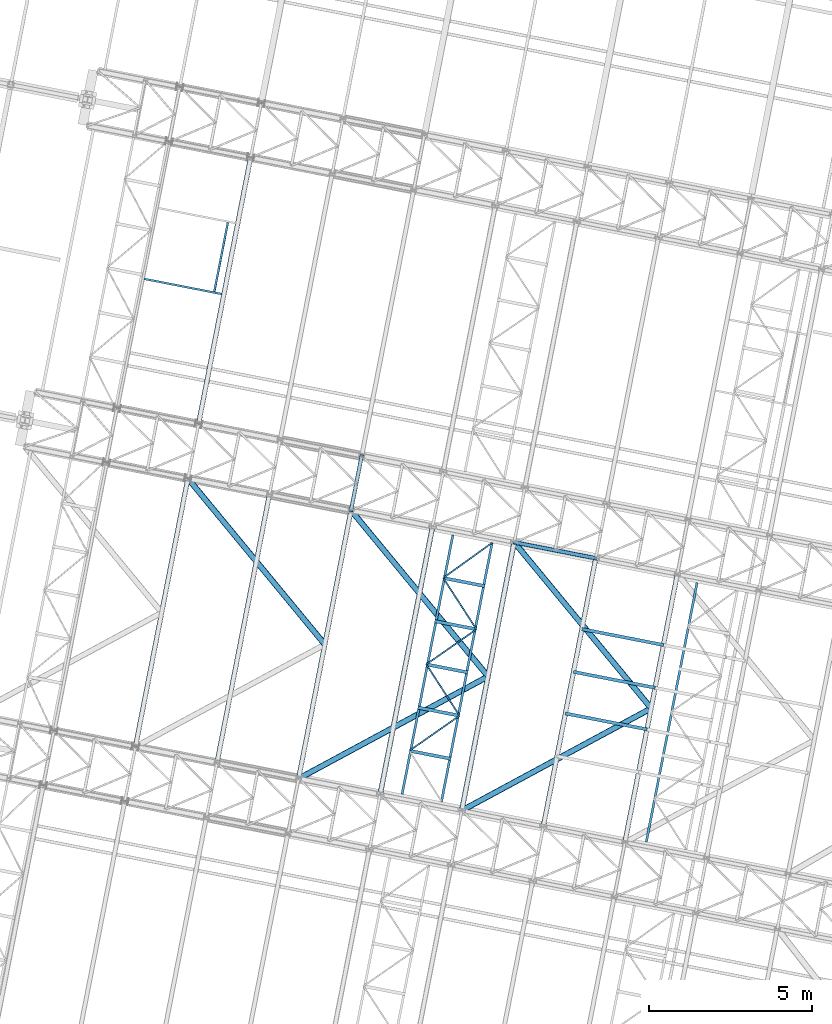
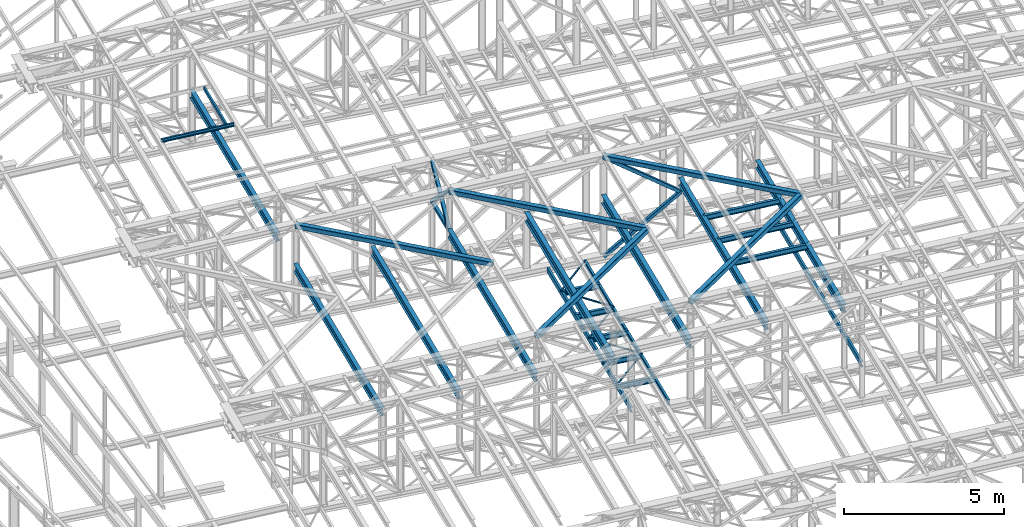
# One storey, part 74 of 215: 32 beams, 4 members, 36 elements without a shape of their own.
"""IFC2X3 building model written with IfcOpenShell, lengths in millimetres."""

from ifc_helpers import new_model, si_unit, frame, origin_with_axes, origin_2d_with_axis, place, context, subcontext, project, spatial, hollow_rectangle, i_section, u_section, extrude, material, type_object, element, aggregate, save


model = new_model("IFC2X3")

# Units and contexts
model_context = context("Model", 3, precision=1e-05, world=origin_with_axes())
body_context = subcontext(model_context, "Body", "Model", "MODEL_VIEW")
ifc_project = project(units=[si_unit("LENGTHUNIT", "METRE", prefix="MILLI"), si_unit("AREAUNIT", "SQUARE_METRE"), si_unit("VOLUMEUNIT", "CUBIC_METRE"), si_unit("MASSUNIT", "GRAM", prefix="KILO"), si_unit("TIMEUNIT", "SECOND"), si_unit("PLANEANGLEUNIT", "RADIAN"), si_unit("SOLIDANGLEUNIT", "STERADIAN"), si_unit("THERMODYNAMICTEMPERATUREUNIT", "DEGREE_CELSIUS"), si_unit("LUMINOUSINTENSITYUNIT", "LUMEN")], contexts=[model_context])

# Site, building, storey
site_placement = place(None, origin_with_axes())
site = spatial("IfcSite", under=ifc_project, at=site_placement, CompositionType="ELEMENT")
building_placement = place(site_placement, origin_with_axes())
building = spatial("IfcBuilding", under=site, at=building_placement, Name="Undefined", CompositionType="ELEMENT")
storey_placement = place(building_placement, origin_with_axes())
storey = spatial("IfcBuildingStorey", under=building, at=storey_placement, Name="Undefined", CompositionType="ELEMENT", Elevation=0.0)

# Assembly, beam
assembly_1_placement = place(storey_placement, origin_with_axes())
assembly_1 = element("IfcElementAssembly", 1, at=assembly_1_placement, inside=storey, Name="Steel Assembly", AssemblyPlace="NOTDEFINED", PredefinedType="RIGID_FRAME")
ifc_material_1 = material(Name="STEEL/S275JR")
beam_type_1 = type_object("IfcBeamType", PredefinedType="NOTDEFINED")
beam_1_placement = place(assembly_1_placement, frame((56068.4883392099, 40051.9911039338, 10796.0000010585), z_axis=(0.981422364268518, -0.191859461052493, -0.000300197000082615), x_axis=(0.191859470081235, 0.981422408415534, 0.0)))
beam_1 = element("IfcBeam", 2, at=beam_1_placement, type_object=beam_type_1, material=ifc_material_1, context=body_context, shape_type="SweptSolid", body=[
    extrude(hollow_rectangle(XDim=120.0, YDim=120.0, WallThickness=5.0, InnerFilletRadius=5.0, OuterFilletRadius=10.0, at=origin_2d_with_axis()), frame((1699.99999941724, 1.81898940354586e-12, 0.0), z_axis=(-1.0, 0.0, 0.0), x_axis=(-6.93889390390723e-18, -1.0, -3.46944695195361e-18)), (0.0, 0.0, 1.0), 1700.0),
])
aggregate(assembly_1, [beam_1])

assembly_2_placement = place(storey_placement, origin_with_axes())
assembly_2 = element("IfcElementAssembly", 3, at=assembly_2_placement, inside=storey, Name="Steel Assembly", AssemblyPlace="NOTDEFINED", PredefinedType="RIGID_FRAME")
beam_type_2 = type_object("IfcBeamType", PredefinedType="NOTDEFINED")
beam_2_placement = place(assembly_2_placement, frame((59388.9839819225, 33770.6286614, 8745.0), z_axis=(0.0, 0.0, -1.0), x_axis=(-0.819693302763381, -0.57280266183465, 0.0)))
beam_2 = element("IfcBeam", 4, at=beam_2_placement, type_object=beam_type_2, material=ifc_material_1, context=body_context, shape_type="SweptSolid", body=[
    extrude(hollow_rectangle(XDim=50.0, YDim=50.0, WallThickness=3.0, InnerFilletRadius=3.0, OuterFilletRadius=6.0, at=origin_2d_with_axis()), frame((1872.18331006399, -1.71506235268826e-12, -1.81898940354586e-12), z_axis=(-1.0, 0.0, 0.0), x_axis=(-6.93889390390723e-18, -1.0, -3.46944695195361e-18)), (0.0, 0.0, 1.0), 1872.2),
])
aggregate(assembly_2, [beam_2])

assembly_3_placement = place(storey_placement, origin_with_axes())
assembly_3 = element("IfcElementAssembly", 5, at=assembly_3_placement, inside=storey, Name="Steel Assembly", AssemblyPlace="NOTDEFINED", PredefinedType="RIGID_FRAME")
beam_3_placement = place(assembly_3_placement, frame((58371.9008317393, 35341.8559067744, 8745.0), z_axis=(0.0, 0.0, -1.0), x_axis=(0.54340443190272, -0.839471037849718, 0.0)))
beam_3 = element("IfcBeam", 6, at=beam_3_placement, type_object=beam_type_2, material=ifc_material_1, context=body_context, shape_type="SweptSolid", body=[
    extrude(hollow_rectangle(XDim=50.0, YDim=50.0, WallThickness=3.0, InnerFilletRadius=3.0, OuterFilletRadius=6.0, at=origin_2d_with_axis()), frame((1871.68725783601, 1.03899514427353e-13, 0.0), z_axis=(-1.0, 0.0, 0.0), x_axis=(-6.93889390390723e-18, -1.0, -3.46944695195361e-18)), (0.0, 0.0, 1.0), 1871.7),
])
aggregate(assembly_3, [beam_3])

assembly_4_placement = place(storey_placement, origin_with_axes())
assembly_4 = element("IfcElementAssembly", 7, at=assembly_4_placement, inside=storey, Name="Steel Assembly", AssemblyPlace="NOTDEFINED", PredefinedType="RIGID_FRAME")
beam_4_placement = place(assembly_4_placement, frame((59906.5169523149, 36414.2474905055, 8745.0), z_axis=(0.0, 0.0, -1.0), x_axis=(-0.819693302763381, -0.57280266183465, 0.0)))
beam_4 = element("IfcBeam", 8, at=beam_4_placement, type_object=beam_type_2, material=ifc_material_1, context=body_context, shape_type="SweptSolid", body=[
    extrude(hollow_rectangle(XDim=50.0, YDim=50.0, WallThickness=3.0, InnerFilletRadius=3.0, OuterFilletRadius=6.0, at=origin_2d_with_axis()), frame((1872.18331006399, -1.71506235268826e-12, -1.81898940354586e-12), z_axis=(-1.0, 0.0, 0.0), x_axis=(-6.93889390390723e-18, -1.0, -3.46944695195361e-18)), (0.0, 0.0, 1.0), 1872.2),
])
aggregate(assembly_4, [beam_4])

assembly_5_placement = place(storey_placement, origin_with_axes())
assembly_5 = element("IfcElementAssembly", 9, at=assembly_5_placement, inside=storey, Name="Steel Assembly", AssemblyPlace="NOTDEFINED", PredefinedType="RIGID_FRAME")
beam_5_placement = place(assembly_5_placement, frame((58889.4338021317, 37985.47473588, 8745.0), z_axis=(0.0, 0.0, -1.0), x_axis=(0.54340443190272, -0.839471037849718, 0.0)))
beam_5 = element("IfcBeam", 10, at=beam_5_placement, type_object=beam_type_2, material=ifc_material_1, context=body_context, shape_type="SweptSolid", body=[
    extrude(hollow_rectangle(XDim=50.0, YDim=50.0, WallThickness=3.0, InnerFilletRadius=3.0, OuterFilletRadius=6.0, at=origin_2d_with_axis()), frame((1871.68725783601, 1.03899514427353e-13, 0.0), z_axis=(-1.0, 0.0, 0.0), x_axis=(-6.93889390390723e-18, -1.0, -3.46944695195361e-18)), (0.0, 0.0, 1.0), 1871.7),
])
aggregate(assembly_5, [beam_5])

assembly_6_placement = place(storey_placement, origin_with_axes())
assembly_6 = element("IfcElementAssembly", 11, at=assembly_6_placement, inside=storey, Name="Steel Assembly", AssemblyPlace="NOTDEFINED", PredefinedType="RIGID_FRAME")
beam_6_placement = place(assembly_6_placement, frame((60379.3501328525, 39057.9928599236, 8745.0), z_axis=(0.0, 0.0, -1.0), x_axis=(-0.811591585333054, -0.584225212239749, 0.0)))
beam_6 = element("IfcBeam", 12, at=beam_6_placement, type_object=beam_type_2, material=ifc_material_1, context=body_context, shape_type="SweptSolid", body=[
    extrude(hollow_rectangle(XDim=50.0, YDim=50.0, WallThickness=3.0, InnerFilletRadius=3.0, OuterFilletRadius=6.0, at=origin_2d_with_axis()), frame((1835.79568552319, -2.03814263857537e-13, 0.0), z_axis=(-1.0, 0.0, 0.0), x_axis=(-6.93889390390723e-18, -1.0, -3.46944695195361e-18)), (0.0, 0.0, 1.0), 1835.8),
])
aggregate(assembly_6, [beam_6])

assembly_7_placement = place(storey_placement, origin_with_axes())
assembly_7 = element("IfcElementAssembly", 13, at=assembly_7_placement, inside=storey, Name="Steel Assembly", AssemblyPlace="NOTDEFINED", PredefinedType="RIGID_FRAME")
ifc_material_2 = material(Name="STEEL/S235JR")
beam_type_3 = type_object("IfcBeamType", Name="UPN140", PredefinedType="NOTDEFINED")
beam_7_placement = place(assembly_7_placement, frame((51886.3079063828, 46748.6428343733, 12209.6470870652), z_axis=(-0.0304080349967745, 0.00594450299936818, 0.999519891893966), x_axis=(0.191921834917674, 0.981410214579016, 1.34299999948354e-06)))
beam_7 = element("IfcBeam", 14, at=beam_7_placement, type_object=beam_type_3, material=ifc_material_2, ObjectType="UPN140", context=body_context, shape_type="SweptSolid", body=[
    extrude(u_section(Depth=140.0, FlangeWidth=60.0, WebThickness=7.0, FlangeThickness=10.0, FilletRadius=10.0, EdgeRadius=5.0, FlangeSlope=0.0798299857122373, at=origin_2d_with_axis()), frame((2150.00000378023, 7.26605124323266e-12, 2.48810634737501e-15), z_axis=(-1.0, 0.0, 0.0), x_axis=(-6.93889390390723e-18, -1.0, -3.46944695195361e-18)), (0.0, 0.0, 1.0), 2150.0),
])
aggregate(assembly_7, [beam_7])

assembly_8_placement = place(storey_placement, origin_with_axes())
assembly_8 = element("IfcElementAssembly", 15, at=assembly_8_placement, inside=storey, Name="Steel Assembly", AssemblyPlace="NOTDEFINED", PredefinedType="RIGID_FRAME")
beam_8_placement = place(assembly_8_placement, frame((49742.0858907209, 47137.3036134857, 12142.1026785298), z_axis=(-0.0304080349967745, 0.00594450299936818, 0.999519891893966), x_axis=(0.9809472788136, -0.191787511963556, 0.0309836479941128)))
beam_8 = element("IfcBeam", 16, at=beam_8_placement, type_object=beam_type_3, material=ifc_material_2, ObjectType="UPN140", context=body_context, shape_type="SweptSolid", body=[
    extrude(u_section(Depth=140.0, FlangeWidth=60.0, WebThickness=7.0, FlangeThickness=10.0, FilletRadius=10.0, EdgeRadius=5.0, FlangeSlope=0.0798299857122373, at=origin_2d_with_axis()), frame((2424.69780127148, -3.7379625959944e-14, 0.0), z_axis=(-1.0, 0.0, 0.0), x_axis=(-6.93889390390723e-18, -1.0, -3.46944695195361e-18)), (0.0, 0.0, 1.0), 2424.7),
])
aggregate(assembly_8, [beam_8])

assembly_9_placement = place(storey_placement, origin_with_axes())
assembly_9 = element("IfcElementAssembly", 17, at=assembly_9_placement, inside=storey, Name="Steel Assembly", AssemblyPlace="NOTDEFINED", PredefinedType="RIGID_FRAME")
beam_type_4 = type_object("IfcBeamType", Name="UPN200", PredefinedType="NOTDEFINED")
beam_9_placement = place(assembly_9_placement, frame((59185.001716299, 39300.0796500561, 8670.00000003361), z_axis=(0.0, 0.0, -1.0), x_axis=(-0.192120010045405, -0.981371439231932, 0.0)))
beam_9 = element("IfcBeam", 18, at=beam_9_placement, type_object=beam_type_4, material=ifc_material_1, ObjectType="UPN200", context=body_context, shape_type="SweptSolid", body=[
    extrude(u_section(Depth=200.0, FlangeWidth=75.0, WebThickness=8.5, FlangeThickness=11.5, FilletRadius=11.5, EdgeRadius=6.0, FlangeSlope=0.0798299857122373, at=origin_2d_with_axis()), frame((8081.40136371167, 0.0, 0.0), z_axis=(-1.0, 0.0, 0.0), x_axis=(-6.93889390390723e-18, -1.0, -3.46944695195361e-18)), (0.0, 0.0, 1.0), 8081.4),
])
aggregate(assembly_9, [beam_9])

assembly_10_placement = place(storey_placement, origin_with_axes())
assembly_10 = element("IfcElementAssembly", 19, at=assembly_10_placement, inside=storey, Name="Steel Assembly", AssemblyPlace="NOTDEFINED", PredefinedType="RIGID_FRAME")
beam_10_placement = place(assembly_10_placement, frame((58834.648904857, 31134.2149317573, 8670.00000000005), z_axis=(0.0, 0.0, -1.0), x_axis=(0.192120705997516, 0.981371302987313, 0.0)))
beam_10 = element("IfcBeam", 20, at=beam_10_placement, type_object=beam_type_4, material=ifc_material_1, ObjectType="UPN200", context=body_context, shape_type="SweptSolid", body=[
    extrude(u_section(Depth=200.0, FlangeWidth=75.0, WebThickness=8.5, FlangeThickness=11.5, FilletRadius=11.5, EdgeRadius=6.0, FlangeSlope=0.0798299857122373, at=origin_2d_with_axis()), frame((8081.40136371167, 0.0, 0.0), z_axis=(-1.0, 0.0, 0.0), x_axis=(-6.93889390390723e-18, -1.0, -3.46944695195361e-18)), (0.0, 0.0, 1.0), 8081.4),
])
aggregate(assembly_10, [beam_10])

assembly_11_placement = place(storey_placement, origin_with_axes())
assembly_11 = element("IfcElementAssembly", 21, at=assembly_11_placement, inside=storey, Name="Steel Assembly", AssemblyPlace="NOTDEFINED", PredefinedType="RIGID_FRAME")
beam_11_placement = place(assembly_11_placement, frame((66657.3309576963, 37839.3049389897, 8670.00000003361), z_axis=(0.0, 0.0, -1.0), x_axis=(-0.192122339055983, -0.981370983285963, 0.0)))
beam_11 = element("IfcBeam", 22, at=beam_11_placement, type_object=beam_type_4, material=ifc_material_1, ObjectType="UPN200", context=body_context, shape_type="SweptSolid", body=[
    extrude(u_section(Depth=200.0, FlangeWidth=75.0, WebThickness=8.5, FlangeThickness=11.5, FilletRadius=11.5, EdgeRadius=6.0, FlangeSlope=0.0798299857122373, at=origin_2d_with_axis()), frame((8081.40136371167, 0.0, 0.0), z_axis=(-1.0, 0.0, 0.0), x_axis=(-6.93889390390723e-18, -1.0, -3.46944695195361e-18)), (0.0, 0.0, 1.0), 8081.4),
])
aggregate(assembly_11, [beam_11])

# Assembly, member
assembly_12_placement = place(storey_placement, origin_with_axes())
assembly_12 = element("IfcElementAssembly", 23, at=assembly_12_placement, inside=storey, Name="Steel Assembly", AssemblyPlace="NOTDEFINED", PredefinedType="RIGID_FRAME")
member_type = type_object("IfcMemberType", PredefinedType="NOTDEFINED")
member_1_placement = place(assembly_12_placement, frame((56394.649437903, 41720.409197756, 10796.0000010567), z_axis=(0.981461316285517, -0.191660209055757, 0.000221133000063429), x_axis=(-0.1413283100442, -0.722939399226104, 0.676302398211518)))
member_1 = element("IfcMember", 24, at=member_1_placement, type_object=member_type, material=ifc_material_1, context=body_context, shape_type="SweptSolid", body=[
    extrude(hollow_rectangle(XDim=120.0, YDim=120.0, WallThickness=5.0, InnerFilletRadius=5.0, OuterFilletRadius=10.0, at=origin_2d_with_axis()), frame((2307.82564529445, -1.28110058411315e-13, 8.31339197405457e-14), z_axis=(-1.0, 0.0, 0.0), x_axis=(-6.93889390390723e-18, -1.0, -3.46944695195361e-18)), (0.0, 0.0, 1.0), 2307.8),
])
aggregate(assembly_12, [member_1])

assembly_13_placement = place(storey_placement, origin_with_axes())
assembly_13 = element("IfcElementAssembly", 25, at=assembly_13_placement, inside=storey, Name="Steel Assembly", AssemblyPlace="NOTDEFINED", PredefinedType="RIGID_FRAME")
member_2_placement = place(assembly_13_placement, frame((56068.4883392099, 40051.9911039338, 10796.0000010585), z_axis=(0.981461316285734, -0.1916602090558, -0.000221132000064958), x_axis=(0.141328309922255, 0.722939402602315, 0.67630239462797)))
member_2 = element("IfcMember", 26, at=member_2_placement, type_object=member_type, material=ifc_material_1, context=body_context, shape_type="SweptSolid", body=[
    extrude(hollow_rectangle(XDim=120.0, YDim=120.0, WallThickness=5.0, InnerFilletRadius=5.0, OuterFilletRadius=10.0, at=origin_2d_with_axis()), frame((2307.82564529445, -1.28110058411315e-13, 8.31339197405457e-14), z_axis=(-1.0, 0.0, 0.0), x_axis=(-6.93889390390723e-18, -1.0, -3.46944695195361e-18)), (0.0, 0.0, 1.0), 2307.8),
])
aggregate(assembly_13, [member_2])

assembly_14_placement = place(storey_placement, origin_with_axes())
assembly_14 = element("IfcElementAssembly", 27, at=assembly_14_placement, inside=storey, Name="Steel Assembly", AssemblyPlace="NOTDEFINED", PredefinedType="RIGID_FRAME")
member_3_placement = place(assembly_14_placement, frame((61060.8069352431, 39075.3484803415, 8655.0000016707), z_axis=(0.586579985276589, -0.114671755054075, -0.801732068378043), x_axis=(0.786837687269709, -0.153820555052726, 0.597683604204872)))
member_3 = element("IfcMember", 28, at=member_3_placement, type_object=member_type, material=ifc_material_1, context=body_context, shape_type="SweptSolid", body=[
    extrude(hollow_rectangle(XDim=120.0, YDim=120.0, WallThickness=5.0, InnerFilletRadius=5.0, OuterFilletRadius=10.0, at=origin_2d_with_axis()), frame((3174.34353524926, -3.64367411917281e-14, -3.63797880709171e-12), z_axis=(-1.0, 0.0, 0.0), x_axis=(-6.93889390390723e-18, -1.0, -3.46944695195361e-18)), (0.0, 0.0, 1.0), 3174.3),
])
aggregate(assembly_14, [member_3])

assembly_15_placement = place(storey_placement, origin_with_axes())
assembly_15 = element("IfcElementAssembly", 29, at=assembly_15_placement, inside=storey, Name="Steel Assembly", AssemblyPlace="NOTDEFINED", PredefinedType="RIGID_FRAME")
member_4_placement = place(assembly_15_placement, frame((61065.6495561053, 39075.0898102343, 12449.5061705353), z_axis=(-0.5871579940314, 0.114784234006137, -0.80129274904285), x_axis=(0.786406660116399, -0.153735599022755, -0.598272455088553)))
member_4 = element("IfcMember", 30, at=member_4_placement, type_object=member_type, material=ifc_material_1, context=body_context, shape_type="SweptSolid", body=[
    extrude(hollow_rectangle(XDim=120.0, YDim=120.0, WallThickness=5.0, InnerFilletRadius=5.0, OuterFilletRadius=10.0, at=origin_2d_with_axis()), frame((3171.03698575571, 7.28100941696481e-12, -3.52055827352395e-13), z_axis=(-1.0, 0.0, 0.0), x_axis=(-6.93889390390723e-18, -1.0, -3.46944695195361e-18)), (0.0, 0.0, 1.0), 3171.0),
])
aggregate(assembly_15, [member_4])

# Assembly, beam
assembly_16_placement = place(storey_placement, origin_with_axes())
assembly_16 = element("IfcElementAssembly", 31, at=assembly_16_placement, inside=storey, Name="Steel Assembly", AssemblyPlace="NOTDEFINED", PredefinedType="RIGID_FRAME")
beam_type_5 = type_object("IfcBeamType", PredefinedType="NOTDEFINED")
beam_12_placement = place(assembly_16_placement, frame((55270.4855326497, 35948.1553562493, 12311.8085914758), z_axis=(-0.0304080349967745, 0.00594450299936818, 0.999519891893966), x_axis=(-0.636209844962318, 0.771144499954326, -0.023941456998582)))
beam_12 = element("IfcBeam", 32, at=beam_12_placement, type_object=beam_type_5, material=ifc_material_1, context=body_context, shape_type="SweptSolid", body=[
    extrude(hollow_rectangle(XDim=180.0, YDim=180.0, WallThickness=8.0, InnerFilletRadius=12.0, OuterFilletRadius=20.0, at=origin_2d_with_axis()), frame((6586.31471164171, 8.67261906526822e-13, 1.84184027304677e-12), z_axis=(-1.0, 0.0, 0.0), x_axis=(-6.93889390390723e-18, -1.0, -3.46944695195361e-18)), (0.0, 0.0, 1.0), 6586.3),
])
aggregate(assembly_16, [beam_12])

assembly_17_placement = place(storey_placement, origin_with_axes())
assembly_17 = element("IfcElementAssembly", 33, at=assembly_17_placement, inside=storey, Name="Steel Assembly", AssemblyPlace="NOTDEFINED", PredefinedType="RIGID_FRAME")
beam_13_placement = place(assembly_17_placement, frame((60262.9343498152, 34972.1753783833, 12469.4965740085), z_axis=(-0.0304080349967745, 0.00594450299936818, 0.999519891893966), x_axis=(-0.879777562863468, -0.474782314926319, -0.0239414559962845)))
beam_13 = element("IfcBeam", 34, at=beam_13_placement, type_object=beam_type_5, material=ifc_material_1, context=body_context, shape_type="SweptSolid", body=[
    extrude(hollow_rectangle(XDim=180.0, YDim=180.0, WallThickness=8.0, InnerFilletRadius=12.0, OuterFilletRadius=20.0, at=origin_2d_with_axis()), frame((6586.3148658864, 6.71601352153469e-13, 0.0), z_axis=(-1.0, 0.0, 0.0), x_axis=(-6.93889390390723e-18, -1.0, -3.46944695195361e-18)), (0.0, 0.0, 1.0), 6586.3),
])
aggregate(assembly_17, [beam_13])

assembly_18_placement = place(storey_placement, origin_with_axes())
assembly_18 = element("IfcElementAssembly", 35, at=assembly_18_placement, inside=storey, Name="Steel Assembly", AssemblyPlace="NOTDEFINED", PredefinedType="RIGID_FRAME")
beam_14_placement = place(assembly_18_placement, frame((60262.9343498152, 34972.1753783833, 12469.4965740085), z_axis=(-0.0304080349967745, 0.00594450299936818, 0.999519891893966), x_axis=(-0.636209844962318, 0.771144499954326, -0.023941456998582)))
beam_14 = element("IfcBeam", 36, at=beam_14_placement, type_object=beam_type_5, material=ifc_material_1, context=body_context, shape_type="SweptSolid", body=[
    extrude(hollow_rectangle(XDim=180.0, YDim=180.0, WallThickness=8.0, InnerFilletRadius=12.0, OuterFilletRadius=20.0, at=origin_2d_with_axis()), frame((6586.31471164171, 8.67261906526822e-13, 1.84184027304677e-12), z_axis=(-1.0, 0.0, 0.0), x_axis=(-6.93889390390723e-18, -1.0, -3.46944695195361e-18)), (0.0, 0.0, 1.0), 6586.3),
])
aggregate(assembly_18, [beam_14])

assembly_19_placement = place(storey_placement, origin_with_axes())
assembly_19 = element("IfcElementAssembly", 37, at=assembly_19_placement, inside=storey, Name="Steel Assembly", AssemblyPlace="NOTDEFINED", PredefinedType="RIGID_FRAME")
beam_15_placement = place(assembly_19_placement, frame((65255.3831659531, 33996.1954007022, 12627.1845565056), z_axis=(-0.0304080349967745, 0.00594450299936818, 0.999519891893966), x_axis=(-0.879777562863468, -0.474782314926319, -0.0239414559962845)))
beam_15 = element("IfcBeam", 38, at=beam_15_placement, type_object=beam_type_5, material=ifc_material_1, context=body_context, shape_type="SweptSolid", body=[
    extrude(hollow_rectangle(XDim=180.0, YDim=180.0, WallThickness=8.0, InnerFilletRadius=12.0, OuterFilletRadius=20.0, at=origin_2d_with_axis()), frame((6586.3148658864, 6.71601352153469e-13, 0.0), z_axis=(-1.0, 0.0, 0.0), x_axis=(-6.93889390390723e-18, -1.0, -3.46944695195361e-18)), (0.0, 0.0, 1.0), 6586.3),
])
aggregate(assembly_19, [beam_15])

assembly_20_placement = place(storey_placement, origin_with_axes())
assembly_20 = element("IfcElementAssembly", 39, at=assembly_20_placement, inside=storey, Name="Steel Assembly", AssemblyPlace="NOTDEFINED", PredefinedType="RIGID_FRAME")
beam_16_placement = place(assembly_20_placement, frame((65255.3831659531, 33996.1954007022, 12627.1845565056), z_axis=(-0.0304080349967745, 0.00594450299936818, 0.999519891893966), x_axis=(-0.636209844962318, 0.771144499954326, -0.023941456998582)))
beam_16 = element("IfcBeam", 40, at=beam_16_placement, type_object=beam_type_5, material=ifc_material_1, context=body_context, shape_type="SweptSolid", body=[
    extrude(hollow_rectangle(XDim=180.0, YDim=180.0, WallThickness=8.0, InnerFilletRadius=12.0, OuterFilletRadius=20.0, at=origin_2d_with_axis()), frame((6586.31471164171, 8.67261906526822e-13, 1.84184027304677e-12), z_axis=(-1.0, 0.0, 0.0), x_axis=(-6.93889390390723e-18, -1.0, -3.46944695195361e-18)), (0.0, 0.0, 1.0), 6586.3),
])
aggregate(assembly_20, [beam_16])

assembly_21_placement = place(storey_placement, origin_with_axes())
assembly_21 = element("IfcElementAssembly", 41, at=assembly_21_placement, inside=storey, Name="Steel Assembly", AssemblyPlace="NOTDEFINED", PredefinedType="RIGID_FRAME")
beam_type_6 = type_object("IfcBeamType", Name="IPE300", PredefinedType="NOTDEFINED")
beam_17_placement = place(assembly_21_placement, frame((51402.1990656539, 42696.3891387643, 10567.0900002997), z_axis=(0.0, 0.0, 1.0), x_axis=(0.191879342079262, 0.981418523405397, 1.00000006478113e-09)))
beam_17 = element("IfcBeam", 42, at=beam_17_placement, type_object=beam_type_6, material=ifc_material_1, Name="SUPPORT", ObjectType="IPE300", context=body_context, shape_type="SweptSolid", body=[
    extrude(i_section(OverallWidth=150.0, OverallDepth=300.0, WebThickness=7.099999905, FlangeThickness=10.69999981, FilletRadius=15.0, at=origin_2d_with_axis()), frame((8306.35394615426, -2.30547635042662e-13, -1.81898940354586e-12), z_axis=(-1.0, 0.0, 0.0), x_axis=(-6.93889390390723e-18, -1.0, -3.46944695195361e-18)), (0.0, 0.0, 1.0), 8306.4),
])
aggregate(assembly_21, [beam_17])

assembly_22_placement = place(storey_placement, origin_with_axes())
assembly_22 = element("IfcElementAssembly", 43, at=assembly_22_placement, inside=storey, Name="Steel Assembly", AssemblyPlace="NOTDEFINED", PredefinedType="RIGID_FRAME")
beam_18_placement = place(assembly_22_placement, frame((64449.1729807095, 29893.9646428684, 11040.1600001886), z_axis=(0.0, 0.0, 1.0), x_axis=(0.191859470081235, 0.981422408415534, 0.0)))
beam_18 = element("IfcBeam", 44, at=beam_18_placement, type_object=beam_type_6, material=ifc_material_1, Name="SUPPORT", ObjectType="IPE300", context=body_context, shape_type="SweptSolid", body=[
    extrude(i_section(OverallWidth=150.0, OverallDepth=300.0, WebThickness=7.099999905, FlangeThickness=10.69999981, FilletRadius=15.0, at=origin_2d_with_axis()), frame((8361.40106173832, 0.0, -1.81898940354586e-12), z_axis=(-1.0, 0.0, 0.0), x_axis=(-6.93889390390723e-18, -1.0, -3.46944695195361e-18)), (0.0, 0.0, 1.0), 8361.4),
])
aggregate(assembly_22, [beam_18])

assembly_23_placement = place(storey_placement, origin_with_axes())
assembly_23 = element("IfcElementAssembly", 45, at=assembly_23_placement, inside=storey, Name="Steel Assembly", AssemblyPlace="NOTDEFINED", PredefinedType="RIGID_FRAME")
beam_19_placement = place(assembly_23_placement, frame((61952.9488773992, 30381.9545029791, 10961.3100002071), z_axis=(0.0, 0.0, 1.0), x_axis=(0.191859470081235, 0.981422408415534, 0.0)))
beam_19 = element("IfcBeam", 46, at=beam_19_placement, type_object=beam_type_6, material=ifc_material_1, Name="SUPPORT", ObjectType="IPE300", context=body_context, shape_type="SweptSolid", body=[
    extrude(i_section(OverallWidth=150.0, OverallDepth=300.0, WebThickness=7.099999905, FlangeThickness=10.69999981, FilletRadius=15.0, at=origin_2d_with_axis()), frame((8361.40106173832, 0.0, -1.81898940354586e-12), z_axis=(-1.0, 0.0, 0.0), x_axis=(-6.93889390390723e-18, -1.0, -3.46944695195361e-18)), (0.0, 0.0, 1.0), 8361.4),
])
aggregate(assembly_23, [beam_19])

assembly_24_placement = place(storey_placement, origin_with_axes())
assembly_24 = element("IfcElementAssembly", 47, at=assembly_24_placement, inside=storey, Name="Steel Assembly", AssemblyPlace="NOTDEFINED", PredefinedType="RIGID_FRAME")
beam_20_placement = place(assembly_24_placement, frame((54464.2765604447, 31845.9240851776, 10724.7800002627), z_axis=(0.0, 0.0, 1.0), x_axis=(0.191859470081235, 0.981422408415534, 0.0)))
beam_20 = element("IfcBeam", 48, at=beam_20_placement, type_object=beam_type_6, material=ifc_material_1, Name="SUPPORT", ObjectType="IPE300", context=body_context, shape_type="SweptSolid", body=[
    extrude(i_section(OverallWidth=150.0, OverallDepth=300.0, WebThickness=7.099999905, FlangeThickness=10.69999981, FilletRadius=15.0, at=origin_2d_with_axis()), frame((8361.40106173832, 0.0, -1.81898940354586e-12), z_axis=(-1.0, 0.0, 0.0), x_axis=(-6.93889390390723e-18, -1.0, -3.46944695195361e-18)), (0.0, 0.0, 1.0), 8361.4),
])
aggregate(assembly_24, [beam_20])

assembly_25_placement = place(storey_placement, origin_with_axes())
assembly_25 = element("IfcElementAssembly", 49, at=assembly_25_placement, inside=storey, Name="Steel Assembly", AssemblyPlace="NOTDEFINED", PredefinedType="RIGID_FRAME")
beam_21_placement = place(assembly_25_placement, frame((51968.0524550749, 32333.9139458882, 10645.9400002812), z_axis=(0.0, 0.0, 1.0), x_axis=(0.191859470081235, 0.981422408415534, 0.0)))
beam_21 = element("IfcBeam", 50, at=beam_21_placement, type_object=beam_type_6, material=ifc_material_1, Name="SUPPORT", ObjectType="IPE300", context=body_context, shape_type="SweptSolid", body=[
    extrude(i_section(OverallWidth=150.0, OverallDepth=300.0, WebThickness=7.099999905, FlangeThickness=10.69999981, FilletRadius=15.0, at=origin_2d_with_axis()), frame((8361.40106173832, 0.0, -1.81898940354586e-12), z_axis=(-1.0, 0.0, 0.0), x_axis=(-6.93889390390723e-18, -1.0, -3.46944695195361e-18)), (0.0, 0.0, 1.0), 8361.4),
])
aggregate(assembly_25, [beam_21])

assembly_26_placement = place(storey_placement, origin_with_axes())
assembly_26 = element("IfcElementAssembly", 51, at=assembly_26_placement, inside=storey, Name="Steel Assembly", AssemblyPlace="NOTDEFINED", PredefinedType="RIGID_FRAME")
beam_22_placement = place(assembly_26_placement, frame((49471.8241781291, 32821.904622204, 10567.0900002997), z_axis=(0.0, 0.0, 1.0), x_axis=(0.191859470081235, 0.981422408415534, 0.0)))
beam_22 = element("IfcBeam", 52, at=beam_22_placement, type_object=beam_type_6, material=ifc_material_1, Name="SUPPORT", ObjectType="IPE300", context=body_context, shape_type="SweptSolid", body=[
    extrude(i_section(OverallWidth=150.0, OverallDepth=300.0, WebThickness=7.099999905, FlangeThickness=10.69999981, FilletRadius=15.0, at=origin_2d_with_axis()), frame((8361.40106173832, 0.0, -1.81898940354586e-12), z_axis=(-1.0, 0.0, 0.0), x_axis=(-6.93889390390723e-18, -1.0, -3.46944695195361e-18)), (0.0, 0.0, 1.0), 8361.4),
])
aggregate(assembly_26, [beam_22])

assembly_27_placement = place(storey_placement, origin_with_axes())
assembly_27 = element("IfcElementAssembly", 53, at=assembly_27_placement, inside=storey, Name="Steel Assembly", AssemblyPlace="NOTDEFINED", PredefinedType="RIGID_FRAME")
beam_type_7 = type_object("IfcBeamType", Name="IPE200", PredefinedType="NOTDEFINED")
beam_23_placement = place(assembly_27_placement, frame((62631.9450860545, 33838.9798226043, 11011.4879375523), z_axis=(0.0303605499861654, -0.00593522099729565, -0.99952139054462), x_axis=(0.980952689077156, -0.191767651015084, 0.030935252002433)))
beam_23 = element("IfcBeam", 54, at=beam_23_placement, type_object=beam_type_7, material=ifc_material_1, ObjectType="IPE200", context=body_context, shape_type="SweptSolid", body=[
    extrude(i_section(OverallWidth=100.0, OverallDepth=200.0, WebThickness=5.599999905, FlangeThickness=8.5, FilletRadius=12.0, at=origin_2d_with_axis()), frame((2544.66727454958, 2.95700928513306e-14, 1.81016081542643e-12), z_axis=(-1.0, 0.0, 0.0), x_axis=(-6.93889390390723e-18, -1.0, -3.46944695195361e-18)), (0.0, 0.0, 1.0), 2544.7),
])
aggregate(assembly_27, [beam_23])

assembly_28_placement = place(storey_placement, origin_with_axes())
assembly_28 = element("IfcElementAssembly", 55, at=assembly_28_placement, inside=storey, Name="Steel Assembly", AssemblyPlace="NOTDEFINED", PredefinedType="RIGID_FRAME")
beam_24_placement = place(assembly_28_placement, frame((62880.7218624847, 35111.5540490606, 11011.4879375534), z_axis=(0.0303605499861654, -0.00593522099729565, -0.99952139054462), x_axis=(0.980952689077156, -0.191767651015084, 0.030935252002433)))
beam_24 = element("IfcBeam", 56, at=beam_24_placement, type_object=beam_type_7, material=ifc_material_1, ObjectType="IPE200", context=body_context, shape_type="SweptSolid", body=[
    extrude(i_section(OverallWidth=100.0, OverallDepth=200.0, WebThickness=5.599999905, FlangeThickness=8.5, FilletRadius=12.0, at=origin_2d_with_axis()), frame((2544.66727454958, 2.95700928513306e-14, 1.81016081542643e-12), z_axis=(-1.0, 0.0, 0.0), x_axis=(-6.93889390390723e-18, -1.0, -3.46944695195361e-18)), (0.0, 0.0, 1.0), 2544.7),
])
aggregate(assembly_28, [beam_24])

assembly_29_placement = place(storey_placement, origin_with_axes())
assembly_29 = element("IfcElementAssembly", 57, at=assembly_29_placement, inside=storey, Name="Steel Assembly", AssemblyPlace="NOTDEFINED", PredefinedType="RIGID_FRAME")
beam_25_placement = place(assembly_29_placement, frame((63136.7197512595, 36420.9291415667, 11011.6080141692), z_axis=(0.0303605499861654, -0.00593522099729565, -0.99952139054462), x_axis=(0.980952689077156, -0.191767651015084, 0.030935252002433)))
beam_25 = element("IfcBeam", 58, at=beam_25_placement, type_object=beam_type_7, material=ifc_material_1, ObjectType="IPE200", context=body_context, shape_type="SweptSolid", body=[
    extrude(i_section(OverallWidth=100.0, OverallDepth=200.0, WebThickness=5.599999905, FlangeThickness=8.5, FilletRadius=12.0, at=origin_2d_with_axis()), frame((2544.66727454958, 2.95700928513306e-14, 1.81016081542643e-12), z_axis=(-1.0, 0.0, 0.0), x_axis=(-6.93889390390723e-18, -1.0, -3.46944695195361e-18)), (0.0, 0.0, 1.0), 2544.7),
])
aggregate(assembly_29, [beam_25])

assembly_30_placement = place(storey_placement, origin_with_axes())
assembly_30 = element("IfcElementAssembly", 59, at=assembly_30_placement, inside=storey, Name="Steel Assembly", AssemblyPlace="NOTDEFINED", PredefinedType="RIGID_FRAME")
beam_26_placement = place(assembly_30_placement, frame((60165.2834375111, 37736.0569050583, 8670.00000000005), z_axis=(0.0, 0.0, -1.0), x_axis=(-0.981422412140383, 0.191859451027444, 0.0)))
beam_26 = element("IfcBeam", 60, at=beam_26_placement, type_object=beam_type_7, material=ifc_material_1, ObjectType="IPE200", context=body_context, shape_type="SweptSolid", body=[
    extrude(i_section(OverallWidth=100.0, OverallDepth=200.0, WebThickness=5.599999905, FlangeThickness=8.5, FilletRadius=12.0, at=origin_2d_with_axis()), frame((1300.00059478047, 0.0, -1.81898940354586e-12), z_axis=(-1.0, 0.0, 0.0), x_axis=(-6.93889390390723e-18, -1.0, -3.46944695195361e-18)), (0.0, 0.0, 1.0), 1300.0),
])
aggregate(assembly_30, [beam_26])

assembly_31_placement = place(storey_placement, origin_with_axes())
assembly_31 = element("IfcElementAssembly", 61, at=assembly_31_placement, inside=storey, Name="Steel Assembly", AssemblyPlace="NOTDEFINED", PredefinedType="RIGID_FRAME")
beam_27_placement = place(assembly_31_placement, frame((59906.5169523149, 36414.2474905055, 8670.00000000005), z_axis=(0.0, 0.0, -1.0), x_axis=(-0.981422412140383, 0.191859451027444, 0.0)))
beam_27 = element("IfcBeam", 62, at=beam_27_placement, type_object=beam_type_7, material=ifc_material_1, ObjectType="IPE200", context=body_context, shape_type="SweptSolid", body=[
    extrude(i_section(OverallWidth=100.0, OverallDepth=200.0, WebThickness=5.599999905, FlangeThickness=8.5, FilletRadius=12.0, at=origin_2d_with_axis()), frame((1300.00059478047, 0.0, -1.81898940354586e-12), z_axis=(-1.0, 0.0, 0.0), x_axis=(-6.93889390390723e-18, -1.0, -3.46944695195361e-18)), (0.0, 0.0, 1.0), 1300.0),
])
aggregate(assembly_31, [beam_27])

assembly_32_placement = place(storey_placement, origin_with_axes())
assembly_32 = element("IfcElementAssembly", 63, at=assembly_32_placement, inside=storey, Name="Steel Assembly", AssemblyPlace="NOTDEFINED", PredefinedType="RIGID_FRAME")
beam_28_placement = place(assembly_32_placement, frame((59647.7504671187, 35092.4380759527, 8670.00000000005), z_axis=(0.0, 0.0, -1.0), x_axis=(-0.981422412140383, 0.191859451027444, 0.0)))
beam_28 = element("IfcBeam", 64, at=beam_28_placement, type_object=beam_type_7, material=ifc_material_1, ObjectType="IPE200", context=body_context, shape_type="SweptSolid", body=[
    extrude(i_section(OverallWidth=100.0, OverallDepth=200.0, WebThickness=5.599999905, FlangeThickness=8.5, FilletRadius=12.0, at=origin_2d_with_axis()), frame((1300.00059478047, 0.0, -1.81898940354586e-12), z_axis=(-1.0, 0.0, 0.0), x_axis=(-6.93889390390723e-18, -1.0, -3.46944695195361e-18)), (0.0, 0.0, 1.0), 1300.0),
])
aggregate(assembly_32, [beam_28])

assembly_33_placement = place(storey_placement, origin_with_axes())
assembly_33 = element("IfcElementAssembly", 65, at=assembly_33_placement, inside=storey, Name="Steel Assembly", AssemblyPlace="NOTDEFINED", PredefinedType="RIGID_FRAME")
beam_29_placement = place(assembly_33_placement, frame((59388.9839819225, 33770.6286614, 8670.00000000005), z_axis=(0.0, 0.0, -1.0), x_axis=(-0.981422412140383, 0.191859451027444, 0.0)))
beam_29 = element("IfcBeam", 66, at=beam_29_placement, type_object=beam_type_7, material=ifc_material_1, ObjectType="IPE200", context=body_context, shape_type="SweptSolid", body=[
    extrude(i_section(OverallWidth=100.0, OverallDepth=200.0, WebThickness=5.599999905, FlangeThickness=8.5, FilletRadius=12.0, at=origin_2d_with_axis()), frame((1300.00059478047, 0.0, -1.81898940354586e-12), z_axis=(-1.0, 0.0, 0.0), x_axis=(-6.93889390390723e-18, -1.0, -3.46944695195361e-18)), (0.0, 0.0, 1.0), 1300.0),
])
aggregate(assembly_33, [beam_29])

assembly_34_placement = place(storey_placement, origin_with_axes())
assembly_34 = element("IfcElementAssembly", 67, at=assembly_34_placement, inside=storey, Name="Steel Assembly", AssemblyPlace="NOTDEFINED", PredefinedType="RIGID_FRAME")
beam_30_placement = place(assembly_34_placement, frame((59130.2174967265, 32448.8192468481, 8670.00000000005), z_axis=(0.0, 0.0, -1.0), x_axis=(-0.981422412140383, 0.191859451027444, 0.0)))
beam_30 = element("IfcBeam", 68, at=beam_30_placement, type_object=beam_type_7, material=ifc_material_1, ObjectType="IPE200", context=body_context, shape_type="SweptSolid", body=[
    extrude(i_section(OverallWidth=100.0, OverallDepth=200.0, WebThickness=5.599999905, FlangeThickness=8.5, FilletRadius=12.0, at=origin_2d_with_axis()), frame((1300.00059478047, 0.0, -1.81898940354586e-12), z_axis=(-1.0, 0.0, 0.0), x_axis=(-6.93889390390723e-18, -1.0, -3.46944695195361e-18)), (0.0, 0.0, 1.0), 1300.0),
])
aggregate(assembly_34, [beam_30])

assembly_35_placement = place(storey_placement, origin_with_axes())
assembly_35 = element("IfcElementAssembly", 69, at=assembly_35_placement, inside=storey, Name="Steel Assembly", AssemblyPlace="NOTDEFINED", PredefinedType="RIGID_FRAME")
beam_type_8 = type_object("IfcBeamType", Name="IPE330", PredefinedType="NOTDEFINED")
beam_31_placement = place(assembly_35_placement, frame((59456.724771343, 30869.9443638365, 10867.4700003382), z_axis=(0.0, 0.0, 1.0), x_axis=(0.191859470081235, 0.981422408415534, 0.0)))
beam_31 = element("IfcBeam", 70, at=beam_31_placement, type_object=beam_type_8, material=ifc_material_1, Name="SUPPORT", ObjectType="IPE330", context=body_context, shape_type="SweptSolid", body=[
    extrude(i_section(OverallWidth=160.0, OverallDepth=330.0, WebThickness=7.5, FlangeThickness=11.5, FilletRadius=18.0, at=origin_2d_with_axis()), frame((8361.40106173832, 0.0, -1.81898940354586e-12), z_axis=(-1.0, 0.0, 0.0), x_axis=(-6.93889390390723e-18, -1.0, -3.46944695195361e-18)), (0.0, 0.0, 1.0), 8361.4),
])
aggregate(assembly_35, [beam_31])

assembly_36_placement = place(storey_placement, origin_with_axes())
assembly_36 = element("IfcElementAssembly", 71, at=assembly_36_placement, inside=storey, Name="Steel Assembly", AssemblyPlace="NOTDEFINED", PredefinedType="RIGID_FRAME")
beam_32_placement = place(assembly_36_placement, frame((56960.5006657154, 31357.9342244988, 10788.6300003659), z_axis=(0.0, 0.0, 1.0), x_axis=(0.191859470081235, 0.981422408415534, 0.0)))
beam_32 = element("IfcBeam", 72, at=beam_32_placement, type_object=beam_type_8, material=ifc_material_1, Name="SUPPORT", ObjectType="IPE330", context=body_context, shape_type="SweptSolid", body=[
    extrude(i_section(OverallWidth=160.0, OverallDepth=330.0, WebThickness=7.5, FlangeThickness=11.5, FilletRadius=18.0, at=origin_2d_with_axis()), frame((8361.40106173832, 0.0, -1.81898940354586e-12), z_axis=(-1.0, 0.0, 0.0), x_axis=(-6.93889390390723e-18, -1.0, -3.46944695195361e-18)), (0.0, 0.0, 1.0), 8361.4),
])
aggregate(assembly_36, [beam_32])

save(model, "model.ifc")
